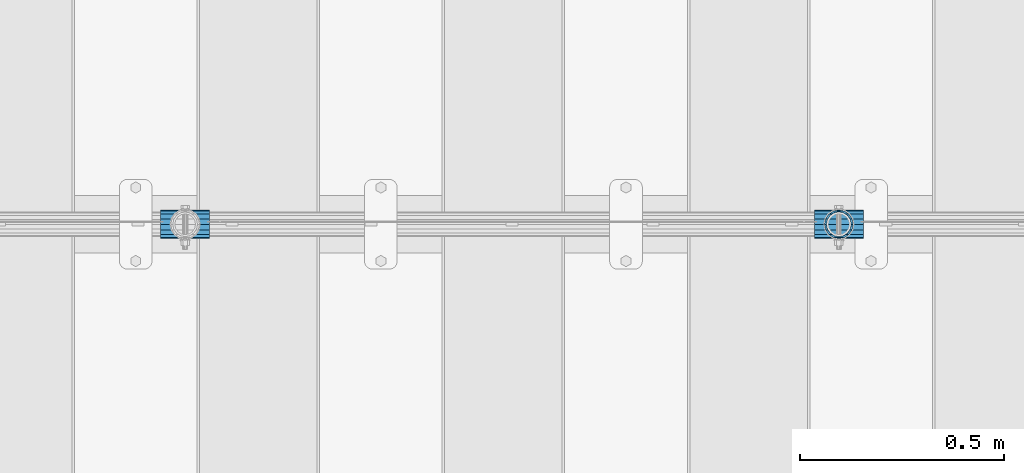
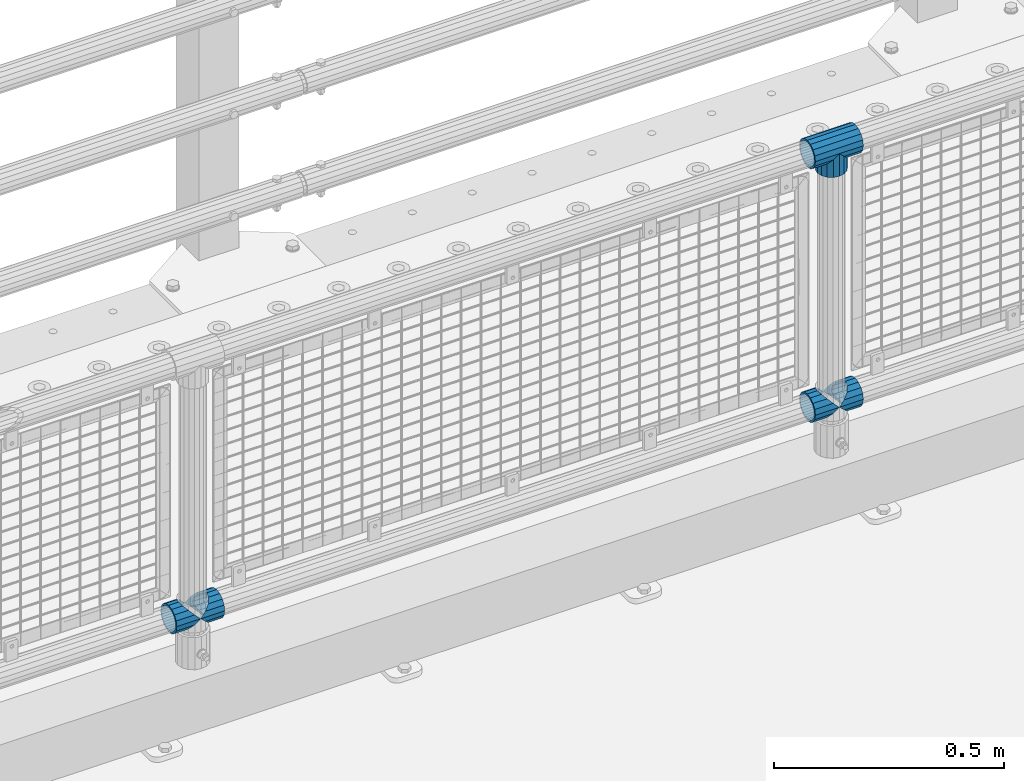
# One storey, part 153 of 247: 6 beams.
"""IFC2X3 building model written with IfcOpenShell, lengths in millimetres."""

from ifc_helpers import new_model, si_unit, frame, origin_with_axes, place, context, subcontext, project, spatial, faceted_brep, material, type_object, element, save


model = new_model("IFC2X3")

# Units and contexts
model_context = context("Model", 3, precision=1e-05, world=origin_with_axes())
body_context = subcontext(model_context, "Body", "Model", "MODEL_VIEW")
ifc_project = project(units=[si_unit("LENGTHUNIT", "METRE", prefix="MILLI"), si_unit("AREAUNIT", "SQUARE_METRE"), si_unit("VOLUMEUNIT", "CUBIC_METRE"), si_unit("MASSUNIT", "GRAM", prefix="KILO"), si_unit("TIMEUNIT", "SECOND"), si_unit("PLANEANGLEUNIT", "RADIAN"), si_unit("SOLIDANGLEUNIT", "STERADIAN"), si_unit("THERMODYNAMICTEMPERATUREUNIT", "DEGREE_CELSIUS"), si_unit("LUMINOUSINTENSITYUNIT", "LUMEN")], contexts=[model_context])

# Site, building, storey
site_placement = place(None, origin_with_axes())
site = spatial("IfcSite", under=ifc_project, at=site_placement, CompositionType="ELEMENT")
building_placement = place(site_placement, origin_with_axes())
building = spatial("IfcBuilding", under=site, at=building_placement, Name="Standard", CompositionType="ELEMENT")
storey_placement = place(building_placement, origin_with_axes())
storey = spatial("IfcBuildingStorey", under=building, at=storey_placement, Name="Undefined", CompositionType="ELEMENT", Elevation=0.0)

# Beams
ifc_material = material(Name="Misc_Undefined")
beam_type = type_object("IfcBeamType", PredefinedType="NOTDEFINED")
beam_1_placement = place(storey_placement, frame((10221.0, 7664.5, 969.849999999999), z_axis=(0.0, 1.0, 0.0), x_axis=(0.0, 0.0, -1.0)))
element("IfcBeam", 1, at=beam_1_placement, inside=storey, type_object=beam_type, material=ifc_material, context=body_context, shape_type="Brep", body=[
    faceted_brep([(0.0, 0.0, 35.1499999999996), (13.4513226476338, 13.4513226476329, 32.4743655677721), (13.4513226476338, -13.4513226476329, 32.4743655677721), (24.8548033587067, -16.3810424080045, -24.8548033587067), (24.8548033587067, -24.8548033587072, -24.8548033587067), (32.4743655677721, -32.4743655677717, -13.4513226476329), (32.4743655677721, -26.8123795176766, -13.4513226476329), (27.1226768591059, -21.4606908090117, -21.4606908090118), (0.0, 0.0, -35.1499999999996), (13.4513226476338, -13.4513226476329, -32.4743655677721), (13.4513226476338, 13.4513226476329, -32.4743655677721), (20.0882031229885, -11.6144421722805, -28.0397438117179), (16.6306603983739, 0.0, -30.3500000000004), (20.0882031229885, 11.6144421722805, -28.0397438117179), (24.8548033587067, 16.3810424080029, -24.8548033587067), (24.8548033587067, 24.8548033587072, -24.8548033587067), (27.1226768591059, 21.4606908090117, -21.4606908090118), (32.4743655677721, 26.8123795176755, -13.4513226476329), (32.4743655677721, 32.4743655677717, -13.4513226476329), (32.8397438117172, 28.0397438117175, -11.6144421722802), (35.1499999999996, 30.35, 0.0), (35.1499999999996, 35.15, 0.0), (32.8397438117172, 28.0397438117175, 11.6144421722802), (32.4743655677721, 26.8123795176755, 13.4513226476329), (32.4743655677721, 32.4743655677717, 13.4513226476329), (27.1226768591096, 21.4606908090117, 21.4606908090118), (24.8548033587067, 16.3810424080046, 24.8548033587067), (24.8548033587067, 24.8548033587072, 24.8548033587067), (20.0882031229812, 11.6144421722805, 28.0397438117179), (16.6306603983649, 0.0, 30.3500000000004), (20.0882031229812, -11.6144421722805, 28.0397438117179), (24.8548033587067, -16.3810424080045, 24.8548033587067), (24.8548033587067, -24.8548033587072, 24.8548033587067), (27.1226768591096, -21.4606908090117, 21.4606908090118), (32.4743655677721, -26.8123795176755, 13.4513226476329), (32.4743655677721, -32.4743655677717, 13.4513226476329), (32.8397438117172, -28.0397438117175, 11.6144421722802), (35.1499999999996, -30.35, 0.0), (35.1499999999996, -35.15, 0.0), (32.8397438117172, -28.0397438117175, -11.6144421722802), (60.1499999999996, -24.8548033587072, -24.8548033587067), (60.1499999999996, -32.4743655677717, -13.4513226476329), (60.1499999999996, -13.4513226476329, -32.4743655677721), (60.1499999999996, 0.0, -35.1499999999996), (60.1499999999996, 13.4513226476329, -32.4743655677721), (60.1499999999996, 24.8548033587072, -24.8548033587067), (60.1499999999996, 32.4743655677717, -13.4513226476329), (60.1499999999996, 35.15, 0.0), (60.1499999999996, 32.4743655677717, 13.4513226476329), (60.1499999999996, 24.8548033587072, 24.8548033587067), (60.1499999999996, 13.4513226476329, 32.4743655677721), (60.1499999999996, 0.0, 35.1499999999996), (60.1499999999996, -13.4513226476329, 32.4743655677721), (60.1499999999996, -24.8548033587072, 24.8548033587067), (60.1499999999996, -32.4743655677717, 13.4513226476329), (60.1499999999996, -35.15, 0.0), (60.1499999999996, -21.4606908090117, 21.4606908090118), (60.1499999999996, -11.6144421722805, 28.0397438117179), (60.1499999999996, 0.0, 30.3500000000004), (60.1499999999996, 11.6144421722805, 28.0397438117179), (60.1499999999996, 21.4606908090117, 21.4606908090118), (60.1499999999996, 28.0397438117175, 11.6144421722802), (60.1499999999996, 30.35, 0.0), (60.1499999999996, 28.0397438117175, -11.6144421722802), (60.1499999999996, 21.4606908090117, -21.4606908090118), (60.1499999999996, 11.6144421722805, -28.0397438117179), (60.1499999999996, 0.0, -30.3500000000004), (60.1499999999996, -11.6144421722805, -28.0397438117179), (60.1499999999996, -21.4606908090117, -21.4606908090118), (60.1499999999996, -28.0397438117175, -11.6144421722802), (60.1499999999996, -30.35, 0.0), (60.1499999999996, -28.0397438117175, 11.6144421722802)], [[[0, 1, 2]], [[3, 4, 5, 6, 7]], [[8, 9, 10]], [[10, 9, 4, 3, 11, 12, 13, 14, 15]], [[15, 14, 16, 17, 18]], [[18, 17, 19, 20, 21]], [[21, 20, 22, 23, 24]], [[24, 23, 25, 26, 27]], [[27, 26, 28, 29, 30, 31, 32, 2, 1]], [[33, 34, 35, 32, 31]], [[36, 37, 38, 35, 34]], [[6, 5, 38, 37, 39]], [[40, 41, 5, 4]], [[42, 40, 4, 9]], [[43, 42, 9, 8]], [[44, 43, 8, 10]], [[45, 44, 10, 15]], [[46, 45, 15, 18]], [[47, 46, 18, 21]], [[48, 47, 21, 24]], [[49, 48, 24, 27]], [[50, 49, 27, 1]], [[51, 50, 1, 0]], [[52, 51, 0, 2]], [[53, 52, 2, 32]], [[54, 53, 32, 35]], [[55, 54, 35, 38]], [[41, 55, 38, 5]], [[40, 42, 43, 44, 45, 46, 47, 48, 49, 50, 51, 52, 53, 54, 55, 41], [56, 57, 58, 59, 60, 61, 62, 63, 64, 65, 66, 67, 68, 69, 70, 71]], [[71, 70, 37, 36]], [[56, 71, 36, 34, 33]], [[57, 56, 33, 31, 30]], [[58, 57, 30, 29]], [[59, 58, 29, 28]], [[25, 60, 59, 28, 26]], [[22, 61, 60, 25, 23]], [[62, 61, 22, 20]], [[63, 62, 20, 19]], [[64, 63, 19, 17, 16]], [[65, 64, 16, 14, 13]], [[66, 65, 13, 12]], [[67, 66, 12, 11]], [[7, 68, 67, 11, 3]], [[39, 69, 68, 7, 6]], [[70, 69, 39, 37]]]),
])
beam_2_placement = place(storey_placement, frame((10160.85, 7664.5, 969.849999999999), z_axis=(0.0, 0.0, 1.0), x_axis=(1.0, 0.0, 0.0)))
element("IfcBeam", 2, at=beam_2_placement, inside=storey, type_object=beam_type, material=ifc_material, context=body_context, shape_type="Brep", body=[
    faceted_brep([(88.1897438117176, -11.6144421722802, -28.0397438117176), (88.1897438117176, -11.6144421722802, -32.8397438117175), (86.9623795176758, -13.4513226476329, -32.4743655677718), (81.6106908090114, -21.4606908090118, -27.1226768591068), (81.6106908090114, -21.4606908090118, -21.4606908090117), (76.5310424080035, -24.8548033587067, -24.8548033587072), (71.7644421722798, -28.0397438117179, -20.0882031229845), (71.7644421722798, -28.0397438117179, -11.6144421722805), (60.1499999999996, -30.3500000000004, -16.6306603983671), (60.1499999999996, -30.35, 0.0), (48.5355578277195, -28.0397438117179, -20.0882031229845), (48.5355578277195, -28.0397438117179, -11.6144421722805), (43.7689575919958, -24.8548033587067, -24.8548033587072), (38.6893091909878, -21.4606908090118, -27.1226768591068), (38.6893091909878, -21.4606908090118, -21.4606908090117), (33.3376204823217, -13.4513226476329, -32.4743655677718), (32.1102561882817, -11.6144421722802, -32.8397438117175), (32.1102561882817, -11.6144421722802, -28.0397438117176), (29.7999999999993, 0.0, -35.15), (29.7999999999993, 0.0, -30.35), (32.1102561882817, 11.6144421722802, -32.8397438117174), (32.1102561882817, 11.6144421722802, -28.0397438117176), (33.3376204823235, 13.4513226476329, -32.4743655677718), (38.6893091909878, 21.4606908090118, -27.122676859108), (38.6893091909878, 21.4606908090118, -21.4606908090117), (43.7689575919976, 24.8548033587067, -24.8548033587072), (48.5355578277195, 28.0397438117179, -20.0882031229829), (48.5355578277195, 28.0397438117179, -11.6144421722805), (60.1499999999996, 30.3500000000004, -16.6306603983655), (60.1499999999996, 30.35, 0.0), (71.7644421722798, 28.0397438117179, -20.0882031229829), (71.7644421722798, 28.0397438117179, -11.6144421722805), (76.5310424080035, 24.8548033587067, -24.8548033587072), (81.6106908090114, 21.4606908090118, -27.122676859108), (81.6106908090114, 21.4606908090118, -21.4606908090117), (86.9623795176758, 13.4513226476329, -32.4743655677718), (88.1897438117176, 11.6144421722802, -32.8397438117174), (88.1897438117176, 11.6144421722802, -28.0397438117176), (90.5, 0.0, -35.15), (90.5, 0.0, -30.35), (0.0, -21.4606908090118, -21.4606908090118), (0.0, -28.0397438117179, -11.6144421722802), (0.0, -11.6144421722802, -28.0397438117179), (0.0, 0.0, -30.3500000000004), (0.0, 11.6144421722802, -28.0397438117179), (0.0, 21.4606908090118, -21.4606908090118), (0.0, 28.0397438117179, -11.6144421722802), (0.0, 30.3500000000004, 0.0), (0.0, 32.4743655677721, -13.4513226476338), (0.0, 35.1499999999996, 0.0), (120.299999999999, 35.1499999999996, 0.0), (120.299999999999, 32.4743655677721, -13.4513226476329), (0.0, 32.4743655677721, 13.4513226476338), (120.299999999999, 32.4743655677721, 13.4513226476329), (0.0, 24.8548033587067, 24.8548033587067), (120.299999999999, 24.8548033587067, 24.8548033587072), (0.0, 13.4513226476329, 32.4743655677721), (120.299999999999, 13.4513226476329, 32.4743655677718), (0.0, 0.0, 35.1499999999996), (120.299999999999, 0.0, 35.15), (0.0, -13.4513226476329, 32.4743655677721), (120.299999999999, -13.4513226476329, 32.4743655677718), (0.0, -24.8548033587067, 24.8548033587067), (120.299999999999, -24.8548033587067, 24.8548033587072), (0.0, -32.4743655677721, 13.4513226476338), (120.299999999999, -32.4743655677721, 13.4513226476329), (0.0, -35.1499999999996, 0.0), (120.299999999999, -35.1499999999996, 0.0), (0.0, -32.4743655677721, -13.4513226476338), (120.299999999999, -32.4743655677721, -13.4513226476329), (0.0, 24.8548033587067, -24.8548033587067), (0.0, 13.4513226476329, -32.4743655677721), (0.0, 0.0, -35.1499999999996), (0.0, -13.4513226476329, -32.4743655677721), (0.0, -24.8548033587067, -24.8548033587067), (0.0, 28.0397438117179, 11.6144421722802), (0.0, 21.4606908090118, 21.4606908090118), (0.0, 11.6144421722802, 28.0397438117179), (0.0, 0.0, 30.3500000000004), (0.0, -11.6144421722802, 28.0397438117179), (0.0, -21.4606908090118, 21.4606908090118), (0.0, -28.0397438117179, 11.6144421722802), (0.0, -30.3500000000004, 0.0), (120.299999999999, -30.3500000000004, 0.0), (120.299999999999, -28.0397438117179, -11.6144421722805), (120.299999999999, -21.4606908090118, -21.4606908090117), (120.299999999999, -11.6144421722802, -28.0397438117176), (120.299999999999, 0.0, -30.35), (120.299999999999, 21.4606908090118, -21.4606908090117), (120.299999999999, 28.0397438117179, -11.6144421722805), (120.299999999999, 11.6144421722802, -28.0397438117176), (120.299999999999, 30.3500000000004, 0.0), (120.299999999999, 28.0397438117179, 11.6144421722805), (120.299999999999, 21.4606908090118, 21.4606908090117), (120.299999999999, 11.6144421722802, 28.0397438117176), (120.299999999999, 0.0, 30.35), (120.299999999999, -11.6144421722802, 28.0397438117176), (120.299999999999, -21.4606908090118, 21.4606908090117), (120.299999999999, -28.0397438117179, 11.6144421722805), (120.299999999999, -24.8548033587067, -24.8548033587072), (120.299999999999, -13.4513226476329, -32.4743655677718), (120.299999999999, 0.0, -35.15), (120.299999999999, 13.4513226476329, -32.4743655677718), (120.299999999999, 24.8548033587067, -24.8548033587072)], [[[0, 1, 2, 3, 4]], [[4, 3, 5, 6, 7]], [[7, 6, 8, 9]], [[9, 8, 10, 11]], [[11, 10, 12, 13, 14]], [[14, 13, 15, 16, 17]], [[17, 16, 18, 19]], [[19, 18, 20, 21]], [[21, 20, 22, 23, 24]], [[24, 23, 25, 26, 27]], [[27, 26, 28, 29]], [[29, 28, 30, 31]], [[31, 30, 32, 33, 34]], [[34, 33, 35, 36, 37]], [[37, 36, 38, 39]], [[39, 38, 1, 0]], [[40, 41, 11, 14]], [[42, 40, 14, 17]], [[43, 42, 17, 19]], [[44, 43, 19, 21]], [[45, 44, 21, 24]], [[46, 45, 24, 27]], [[47, 46, 27, 29]], [[48, 49, 50, 51]], [[49, 52, 53, 50]], [[52, 54, 55, 53]], [[54, 56, 57, 55]], [[56, 58, 59, 57]], [[58, 60, 61, 59]], [[60, 62, 63, 61]], [[62, 64, 65, 63]], [[64, 66, 67, 65]], [[66, 68, 69, 67]], [[64, 62, 60, 58, 56, 54, 52, 49, 48, 70, 71, 72, 73, 74, 68, 66], [41, 40, 42, 43, 44, 45, 46, 47, 75, 76, 77, 78, 79, 80, 81, 82]], [[41, 82, 9, 11]], [[83, 84, 7, 9]], [[84, 85, 4, 7]], [[85, 86, 0, 4]], [[86, 87, 39, 0]], [[88, 89, 31, 34]], [[90, 88, 34, 37]], [[87, 90, 37, 39]], [[89, 91, 29, 31]], [[75, 47, 29, 91, 92]], [[76, 75, 92, 93]], [[77, 76, 93, 94]], [[78, 77, 94, 95]], [[79, 78, 95, 96]], [[80, 79, 96, 97]], [[81, 80, 97, 98]], [[9, 82, 81, 98, 83]], [[99, 100, 101, 102, 103, 51, 50, 53, 55, 57, 59, 61, 63, 65, 67, 69], [97, 96, 95, 94, 93, 92, 91, 89, 88, 90, 87, 86, 85, 84, 83, 98]], [[35, 102, 101, 38, 36]], [[32, 103, 102, 35, 33]], [[28, 26, 25, 70, 48, 51, 103, 32, 30]], [[22, 71, 70, 25, 23]], [[18, 72, 71, 22, 20]], [[73, 72, 18, 16, 15]], [[74, 73, 15, 13, 12]], [[99, 69, 68, 74, 12, 10, 8, 6, 5]], [[100, 99, 5, 3, 2]], [[101, 100, 2, 1, 38]]]),
])
beam_3_placement = place(storey_placement, frame((10160.85, 7664.5, 298.17), z_axis=(0.0, 1.0, 0.0), x_axis=(1.0, 0.0, 0.0)))
element("IfcBeam", 3, at=beam_3_placement, inside=storey, type_object=beam_type, material=ifc_material, context=body_context, shape_type="Brep", body=[
    faceted_brep([(60.1499999999996, 0.0, -35.1499999999996), (46.6986773523668, 13.4513226476329, -32.4743655677721), (46.6986773523668, -13.4513226476329, -32.4743655677721), (33.0273231408919, 21.4606908090117, 21.4606908090118), (27.675634432228, 26.8123795176755, 13.4513226476329), (27.675634432228, 32.4743655677717, 13.4513226476329), (35.2951966412925, 24.8548033587072, 24.8548033587067), (35.2951966412925, 16.3810424080048, 24.8548033587067), (27.3102561882824, 28.0397438117175, 11.6144421722802), (24.9999999999995, 30.35, 0.0), (24.9999999999995, 35.15, 0.0), (27.675634432228, 26.8123795176764, -13.4513226476329), (27.675634432228, 32.4743655677717, -13.4513226476329), (27.310256188282, 28.0397438117175, -11.6144421722802), (35.2951966412925, 16.3810424080032, -24.8548033587067), (35.2951966412925, 24.8548033587072, -24.8548033587067), (33.0273231408928, 21.4606908090117, -21.4606908090118), (40.0617968770157, 11.6144421722805, -28.0397438117179), (43.5193396016348, 0.0, -30.3500000000004), (40.0617968770157, -11.6144421722805, -28.0397438117179), (35.2951966412925, -16.3810424080032, -24.8548033587067), (35.2951966412925, -24.8548033587072, -24.8548033587067), (33.0273231408928, -21.4606908090117, -21.4606908090118), (27.675634432228, -26.8123795176766, -13.4513226476329), (27.675634432228, -32.4743655677717, -13.4513226476329), (27.310256188282, -28.0397438117175, -11.6144421722802), (24.9999999999995, -30.35, 0.0), (24.9999999999995, -35.15, 0.0), (27.3102561882824, -28.0397438117175, 11.6144421722802), (27.675634432228, -26.8123795176764, 13.4513226476329), (27.675634432228, -32.4743655677717, 13.4513226476329), (33.0273231408919, -21.4606908090117, 21.4606908090118), (35.2951966412925, -16.3810424080032, 24.8548033587067), (35.2951966412925, -24.8548033587072, 24.8548033587067), (60.1499999999996, 0.0, 35.1499999999996), (46.6986773523668, -13.4513226476329, 32.4743655677721), (46.6986773523668, 13.4513226476329, 32.4743655677721), (40.0617968770157, -11.6144421722805, 28.0397438117179), (43.519339601633, 0.0, 30.3500000000004), (40.0617968770157, 11.6144421722805, 28.0397438117179), (0.0, -32.4743655677721, -13.4513226476338), (0.0, -24.8548033587067, -24.8548033587067), (0.0, -13.4513226476329, -32.4743655677721), (0.0, 0.0, -35.1499999999996), (0.0, 13.4513226476329, -32.4743655677721), (0.0, 24.8548033587067, -24.8548033587067), (0.0, 32.4743655677721, -13.4513226476338), (0.0, 35.1499999999996, 0.0), (0.0, 32.4743655677721, 13.4513226476338), (0.0, 24.8548033587067, 24.8548033587067), (0.0, 13.4513226476329, 32.4743655677721), (0.0, 0.0, 35.1499999999996), (0.0, -32.4743655677721, 13.4513226476338), (0.0, -35.1499999999996, 0.0), (0.0, -24.8548033587067, 24.8548033587067), (0.0, -13.4513226476329, 32.4743655677721), (0.0, -28.0397438117179, -11.6144421722802), (0.0, -21.4606908090118, -21.4606908090118), (0.0, -11.6144421722802, -28.0397438117179), (0.0, 0.0, -30.3500000000004), (0.0, 11.6144421722802, -28.0397438117179), (0.0, 21.4606908090118, -21.4606908090118), (0.0, 28.0397438117179, -11.6144421722802), (0.0, 30.3500000000004, 0.0), (0.0, 28.0397438117179, 11.6144421722802), (0.0, 21.4606908090118, 21.4606908090118), (0.0, 11.6144421722802, 28.0397438117179), (0.0, 0.0, 30.3500000000004), (0.0, -11.6144421722802, 28.0397438117179), (0.0, -21.4606908090118, 21.4606908090118), (0.0, -28.0397438117179, 11.6144421722802), (0.0, -30.3500000000004, 0.0)], [[[0, 1, 2]], [[3, 4, 5, 6, 7]], [[8, 9, 10, 5, 4]], [[11, 12, 10, 9, 13]], [[14, 15, 12, 11, 16]], [[2, 1, 15, 14, 17, 18, 19, 20, 21]], [[21, 20, 22, 23, 24]], [[24, 23, 25, 26, 27]], [[27, 26, 28, 29, 30]], [[30, 29, 31, 32, 33]], [[34, 35, 36]], [[33, 32, 37, 38, 39, 7, 6, 36, 35]], [[40, 41, 21, 24]], [[41, 42, 2, 21]], [[42, 43, 0, 2]], [[43, 44, 1, 0]], [[44, 45, 15, 1]], [[45, 46, 12, 15]], [[46, 47, 10, 12]], [[47, 48, 5, 10]], [[48, 49, 6, 5]], [[49, 50, 36, 6]], [[50, 51, 34, 36]], [[52, 53, 27, 30]], [[54, 52, 30, 33]], [[55, 54, 33, 35]], [[51, 55, 35, 34]], [[53, 40, 24, 27]], [[52, 54, 55, 51, 50, 49, 48, 47, 46, 45, 44, 43, 42, 41, 40, 53], [56, 57, 58, 59, 60, 61, 62, 63, 64, 65, 66, 67, 68, 69, 70, 71]], [[68, 67, 38, 37]], [[31, 69, 68, 37, 32]], [[28, 70, 69, 31, 29]], [[71, 70, 28, 26]], [[56, 71, 26, 25]], [[57, 56, 25, 23, 22]], [[58, 57, 22, 20, 19]], [[59, 58, 19, 18]], [[60, 59, 18, 17]], [[16, 61, 60, 17, 14]], [[13, 62, 61, 16, 11]], [[63, 62, 13, 9]], [[64, 63, 9, 8]], [[65, 64, 8, 4, 3]], [[66, 65, 3, 7, 39]], [[67, 66, 39, 38]]]),
])
beam_4_placement = place(storey_placement, frame((10221.0, 7664.5, 298.17), z_axis=(0.0, 1.0, 0.0), x_axis=(1.0, 0.0, 0.0)))
element("IfcBeam", 4, at=beam_4_placement, inside=storey, type_object=beam_type, material=ifc_material, context=body_context, shape_type="Brep", body=[
    faceted_brep([(0.0, 0.0, 35.1499999999996), (13.4513226476338, 13.4513226476329, 32.4743655677721), (13.4513226476338, -13.4513226476329, 32.4743655677721), (24.8548033587067, -16.3810424080045, -24.8548033587067), (24.8548033587067, -24.8548033587072, -24.8548033587067), (32.4743655677721, -32.4743655677717, -13.4513226476329), (32.4743655677721, -26.8123795176766, -13.4513226476329), (27.1226768591059, -21.4606908090117, -21.4606908090118), (0.0, 0.0, -35.1499999999996), (13.4513226476338, -13.4513226476329, -32.4743655677721), (13.4513226476338, 13.4513226476329, -32.4743655677721), (20.0882031229885, -11.6144421722805, -28.0397438117179), (16.6306603983739, 0.0, -30.3500000000004), (20.0882031229885, 11.6144421722805, -28.0397438117179), (24.8548033587067, 16.3810424080029, -24.8548033587067), (24.8548033587067, 24.8548033587072, -24.8548033587067), (27.1226768591059, 21.4606908090117, -21.4606908090118), (32.4743655677721, 26.8123795176755, -13.4513226476329), (32.4743655677721, 32.4743655677717, -13.4513226476329), (32.8397438117172, 28.0397438117175, -11.6144421722802), (35.1499999999996, 30.35, 0.0), (35.1499999999996, 35.15, 0.0), (32.8397438117172, 28.0397438117175, 11.6144421722802), (32.4743655677721, 26.8123795176755, 13.4513226476329), (32.4743655677721, 32.4743655677717, 13.4513226476329), (27.1226768591096, 21.4606908090117, 21.4606908090118), (24.8548033587067, 16.3810424080046, 24.8548033587067), (24.8548033587067, 24.8548033587072, 24.8548033587067), (20.0882031229812, 11.6144421722805, 28.0397438117179), (16.6306603983649, 0.0, 30.3500000000004), (20.0882031229812, -11.6144421722805, 28.0397438117179), (24.8548033587067, -16.3810424080045, 24.8548033587067), (24.8548033587067, -24.8548033587072, 24.8548033587067), (27.1226768591096, -21.4606908090117, 21.4606908090118), (32.4743655677721, -26.8123795176755, 13.4513226476329), (32.4743655677721, -32.4743655677717, 13.4513226476329), (32.8397438117172, -28.0397438117175, 11.6144421722802), (35.1499999999996, -30.35, 0.0), (35.1499999999996, -35.15, 0.0), (32.8397438117172, -28.0397438117175, -11.6144421722802), (60.1499999999996, -24.8548033587072, -24.8548033587067), (60.1499999999996, -32.4743655677717, -13.4513226476329), (60.1499999999996, -13.4513226476329, -32.4743655677721), (60.1499999999996, 0.0, -35.1499999999996), (60.1499999999996, 13.4513226476329, -32.4743655677721), (60.1499999999996, 24.8548033587072, -24.8548033587067), (60.1499999999996, 32.4743655677717, -13.4513226476329), (60.1499999999996, 35.15, 0.0), (60.1499999999996, 32.4743655677717, 13.4513226476329), (60.1499999999996, 24.8548033587072, 24.8548033587067), (60.1499999999996, 13.4513226476329, 32.4743655677721), (60.1499999999996, 0.0, 35.1499999999996), (60.1499999999996, -13.4513226476329, 32.4743655677721), (60.1499999999996, -24.8548033587072, 24.8548033587067), (60.1499999999996, -32.4743655677717, 13.4513226476329), (60.1499999999996, -35.15, 0.0), (60.1499999999996, -21.4606908090117, 21.4606908090118), (60.1499999999996, -11.6144421722805, 28.0397438117179), (60.1499999999996, 0.0, 30.3500000000004), (60.1499999999996, 11.6144421722805, 28.0397438117179), (60.1499999999996, 21.4606908090117, 21.4606908090118), (60.1499999999996, 28.0397438117175, 11.6144421722802), (60.1499999999996, 30.35, 0.0), (60.1499999999996, 28.0397438117175, -11.6144421722802), (60.1499999999996, 21.4606908090117, -21.4606908090118), (60.1499999999996, 11.6144421722805, -28.0397438117179), (60.1499999999996, 0.0, -30.3500000000004), (60.1499999999996, -11.6144421722805, -28.0397438117179), (60.1499999999996, -21.4606908090117, -21.4606908090118), (60.1499999999996, -28.0397438117175, -11.6144421722802), (60.1499999999996, -30.35, 0.0), (60.1499999999996, -28.0397438117175, 11.6144421722802)], [[[0, 1, 2]], [[3, 4, 5, 6, 7]], [[8, 9, 10]], [[10, 9, 4, 3, 11, 12, 13, 14, 15]], [[15, 14, 16, 17, 18]], [[18, 17, 19, 20, 21]], [[21, 20, 22, 23, 24]], [[24, 23, 25, 26, 27]], [[27, 26, 28, 29, 30, 31, 32, 2, 1]], [[33, 34, 35, 32, 31]], [[36, 37, 38, 35, 34]], [[6, 5, 38, 37, 39]], [[40, 41, 5, 4]], [[42, 40, 4, 9]], [[43, 42, 9, 8]], [[44, 43, 8, 10]], [[45, 44, 10, 15]], [[46, 45, 15, 18]], [[47, 46, 18, 21]], [[48, 47, 21, 24]], [[49, 48, 24, 27]], [[50, 49, 27, 1]], [[51, 50, 1, 0]], [[52, 51, 0, 2]], [[53, 52, 2, 32]], [[54, 53, 32, 35]], [[55, 54, 35, 38]], [[41, 55, 38, 5]], [[40, 42, 43, 44, 45, 46, 47, 48, 49, 50, 51, 52, 53, 54, 55, 41], [56, 57, 58, 59, 60, 61, 62, 63, 64, 65, 66, 67, 68, 69, 70, 71]], [[71, 70, 37, 36]], [[56, 71, 36, 34, 33]], [[57, 56, 33, 31, 30]], [[58, 57, 30, 29]], [[59, 58, 29, 28]], [[25, 60, 59, 28, 26]], [[22, 61, 60, 25, 23]], [[62, 61, 22, 20]], [[63, 62, 20, 19]], [[64, 63, 19, 17, 16]], [[65, 64, 16, 14, 13]], [[66, 65, 13, 12]], [[67, 66, 12, 11]], [[7, 68, 67, 11, 3]], [[39, 69, 68, 7, 6]], [[70, 69, 39, 37]]]),
])
beam_5_placement = place(storey_placement, frame((8560.85, 7664.5, 298.17), z_axis=(0.0, 1.0, 0.0), x_axis=(1.0, 0.0, 0.0)))
element("IfcBeam", 5, at=beam_5_placement, inside=storey, type_object=beam_type, material=ifc_material, context=body_context, shape_type="Brep", body=[
    faceted_brep([(60.1499999999996, 0.0, -35.1499999999996), (46.6986773523668, 13.4513226476329, -32.4743655677721), (46.6986773523668, -13.4513226476329, -32.4743655677721), (33.0273231408919, 21.4606908090117, 21.4606908090118), (27.675634432228, 26.8123795176755, 13.4513226476329), (27.675634432228, 32.4743655677717, 13.4513226476329), (35.2951966412925, 24.8548033587072, 24.8548033587067), (35.2951966412925, 16.3810424080048, 24.8548033587067), (27.3102561882824, 28.0397438117175, 11.6144421722802), (24.9999999999995, 30.35, 0.0), (24.9999999999995, 35.15, 0.0), (27.675634432228, 26.8123795176764, -13.4513226476329), (27.675634432228, 32.4743655677717, -13.4513226476329), (27.310256188282, 28.0397438117175, -11.6144421722802), (35.2951966412925, 16.3810424080032, -24.8548033587067), (35.2951966412925, 24.8548033587072, -24.8548033587067), (33.0273231408928, 21.4606908090117, -21.4606908090118), (40.0617968770157, 11.6144421722805, -28.0397438117179), (43.5193396016348, 0.0, -30.3500000000004), (40.0617968770157, -11.6144421722805, -28.0397438117179), (35.2951966412925, -16.3810424080032, -24.8548033587067), (35.2951966412925, -24.8548033587072, -24.8548033587067), (33.0273231408928, -21.4606908090117, -21.4606908090118), (27.675634432228, -26.8123795176766, -13.4513226476329), (27.675634432228, -32.4743655677717, -13.4513226476329), (27.310256188282, -28.0397438117175, -11.6144421722802), (24.9999999999995, -30.35, 0.0), (24.9999999999995, -35.15, 0.0), (27.3102561882824, -28.0397438117175, 11.6144421722802), (27.675634432228, -26.8123795176764, 13.4513226476329), (27.675634432228, -32.4743655677717, 13.4513226476329), (33.0273231408919, -21.4606908090117, 21.4606908090118), (35.2951966412925, -16.3810424080032, 24.8548033587067), (35.2951966412925, -24.8548033587072, 24.8548033587067), (60.1499999999996, 0.0, 35.1499999999996), (46.6986773523668, -13.4513226476329, 32.4743655677721), (46.6986773523668, 13.4513226476329, 32.4743655677721), (40.0617968770157, -11.6144421722805, 28.0397438117179), (43.519339601633, 0.0, 30.3500000000004), (40.0617968770157, 11.6144421722805, 28.0397438117179), (0.0, -32.4743655677721, -13.4513226476338), (0.0, -24.8548033587067, -24.8548033587067), (0.0, -13.4513226476329, -32.4743655677721), (0.0, 0.0, -35.1499999999996), (0.0, 13.4513226476329, -32.4743655677721), (0.0, 24.8548033587067, -24.8548033587067), (0.0, 32.4743655677721, -13.4513226476338), (0.0, 35.1499999999996, 0.0), (0.0, 32.4743655677721, 13.4513226476338), (0.0, 24.8548033587067, 24.8548033587067), (0.0, 13.4513226476329, 32.4743655677721), (0.0, 0.0, 35.1499999999996), (0.0, -32.4743655677721, 13.4513226476338), (0.0, -35.1499999999996, 0.0), (0.0, -24.8548033587067, 24.8548033587067), (0.0, -13.4513226476329, 32.4743655677721), (0.0, -28.0397438117179, -11.6144421722802), (0.0, -21.4606908090118, -21.4606908090118), (0.0, -11.6144421722802, -28.0397438117179), (0.0, 0.0, -30.3500000000004), (0.0, 11.6144421722802, -28.0397438117179), (0.0, 21.4606908090118, -21.4606908090118), (0.0, 28.0397438117179, -11.6144421722802), (0.0, 30.3500000000004, 0.0), (0.0, 28.0397438117179, 11.6144421722802), (0.0, 21.4606908090118, 21.4606908090118), (0.0, 11.6144421722802, 28.0397438117179), (0.0, 0.0, 30.3500000000004), (0.0, -11.6144421722802, 28.0397438117179), (0.0, -21.4606908090118, 21.4606908090118), (0.0, -28.0397438117179, 11.6144421722802), (0.0, -30.3500000000004, 0.0)], [[[0, 1, 2]], [[3, 4, 5, 6, 7]], [[8, 9, 10, 5, 4]], [[11, 12, 10, 9, 13]], [[14, 15, 12, 11, 16]], [[2, 1, 15, 14, 17, 18, 19, 20, 21]], [[21, 20, 22, 23, 24]], [[24, 23, 25, 26, 27]], [[27, 26, 28, 29, 30]], [[30, 29, 31, 32, 33]], [[34, 35, 36]], [[33, 32, 37, 38, 39, 7, 6, 36, 35]], [[40, 41, 21, 24]], [[41, 42, 2, 21]], [[42, 43, 0, 2]], [[43, 44, 1, 0]], [[44, 45, 15, 1]], [[45, 46, 12, 15]], [[46, 47, 10, 12]], [[47, 48, 5, 10]], [[48, 49, 6, 5]], [[49, 50, 36, 6]], [[50, 51, 34, 36]], [[52, 53, 27, 30]], [[54, 52, 30, 33]], [[55, 54, 33, 35]], [[51, 55, 35, 34]], [[53, 40, 24, 27]], [[52, 54, 55, 51, 50, 49, 48, 47, 46, 45, 44, 43, 42, 41, 40, 53], [56, 57, 58, 59, 60, 61, 62, 63, 64, 65, 66, 67, 68, 69, 70, 71]], [[68, 67, 38, 37]], [[31, 69, 68, 37, 32]], [[28, 70, 69, 31, 29]], [[71, 70, 28, 26]], [[56, 71, 26, 25]], [[57, 56, 25, 23, 22]], [[58, 57, 22, 20, 19]], [[59, 58, 19, 18]], [[60, 59, 18, 17]], [[16, 61, 60, 17, 14]], [[13, 62, 61, 16, 11]], [[63, 62, 13, 9]], [[64, 63, 9, 8]], [[65, 64, 8, 4, 3]], [[66, 65, 3, 7, 39]], [[67, 66, 39, 38]]]),
])
beam_6_placement = place(storey_placement, frame((8621.0, 7664.5, 298.17), z_axis=(0.0, 1.0, 0.0), x_axis=(1.0, 0.0, 0.0)))
element("IfcBeam", 6, at=beam_6_placement, inside=storey, type_object=beam_type, material=ifc_material, context=body_context, shape_type="Brep", body=[
    faceted_brep([(0.0, 0.0, 35.1499999999996), (13.4513226476338, 13.4513226476329, 32.4743655677721), (13.4513226476338, -13.4513226476329, 32.4743655677721), (24.8548033587067, -16.3810424080045, -24.8548033587067), (24.8548033587067, -24.8548033587072, -24.8548033587067), (32.4743655677721, -32.4743655677717, -13.4513226476329), (32.4743655677721, -26.8123795176766, -13.4513226476329), (27.1226768591059, -21.4606908090117, -21.4606908090118), (0.0, 0.0, -35.1499999999996), (13.4513226476338, -13.4513226476329, -32.4743655677721), (13.4513226476338, 13.4513226476329, -32.4743655677721), (20.0882031229885, -11.6144421722805, -28.0397438117179), (16.6306603983739, 0.0, -30.3500000000004), (20.0882031229885, 11.6144421722805, -28.0397438117179), (24.8548033587067, 16.3810424080029, -24.8548033587067), (24.8548033587067, 24.8548033587072, -24.8548033587067), (27.1226768591059, 21.4606908090117, -21.4606908090118), (32.4743655677721, 26.8123795176755, -13.4513226476329), (32.4743655677721, 32.4743655677717, -13.4513226476329), (32.8397438117172, 28.0397438117175, -11.6144421722802), (35.1499999999996, 30.35, 0.0), (35.1499999999996, 35.15, 0.0), (32.8397438117172, 28.0397438117175, 11.6144421722802), (32.4743655677721, 26.8123795176755, 13.4513226476329), (32.4743655677721, 32.4743655677717, 13.4513226476329), (27.1226768591096, 21.4606908090117, 21.4606908090118), (24.8548033587067, 16.3810424080046, 24.8548033587067), (24.8548033587067, 24.8548033587072, 24.8548033587067), (20.0882031229812, 11.6144421722805, 28.0397438117179), (16.6306603983649, 0.0, 30.3500000000004), (20.0882031229812, -11.6144421722805, 28.0397438117179), (24.8548033587067, -16.3810424080045, 24.8548033587067), (24.8548033587067, -24.8548033587072, 24.8548033587067), (27.1226768591096, -21.4606908090117, 21.4606908090118), (32.4743655677721, -26.8123795176755, 13.4513226476329), (32.4743655677721, -32.4743655677717, 13.4513226476329), (32.8397438117172, -28.0397438117175, 11.6144421722802), (35.1499999999996, -30.35, 0.0), (35.1499999999996, -35.15, 0.0), (32.8397438117172, -28.0397438117175, -11.6144421722802), (60.1499999999996, -24.8548033587072, -24.8548033587067), (60.1499999999996, -32.4743655677717, -13.4513226476329), (60.1499999999996, -13.4513226476329, -32.4743655677721), (60.1499999999996, 0.0, -35.1499999999996), (60.1499999999996, 13.4513226476329, -32.4743655677721), (60.1499999999996, 24.8548033587072, -24.8548033587067), (60.1499999999996, 32.4743655677717, -13.4513226476329), (60.1499999999996, 35.15, 0.0), (60.1499999999996, 32.4743655677717, 13.4513226476329), (60.1499999999996, 24.8548033587072, 24.8548033587067), (60.1499999999996, 13.4513226476329, 32.4743655677721), (60.1499999999996, 0.0, 35.1499999999996), (60.1499999999996, -13.4513226476329, 32.4743655677721), (60.1499999999996, -24.8548033587072, 24.8548033587067), (60.1499999999996, -32.4743655677717, 13.4513226476329), (60.1499999999996, -35.15, 0.0), (60.1499999999996, -21.4606908090117, 21.4606908090118), (60.1499999999996, -11.6144421722805, 28.0397438117179), (60.1499999999996, 0.0, 30.3500000000004), (60.1499999999996, 11.6144421722805, 28.0397438117179), (60.1499999999996, 21.4606908090117, 21.4606908090118), (60.1499999999996, 28.0397438117175, 11.6144421722802), (60.1499999999996, 30.35, 0.0), (60.1499999999996, 28.0397438117175, -11.6144421722802), (60.1499999999996, 21.4606908090117, -21.4606908090118), (60.1499999999996, 11.6144421722805, -28.0397438117179), (60.1499999999996, 0.0, -30.3500000000004), (60.1499999999996, -11.6144421722805, -28.0397438117179), (60.1499999999996, -21.4606908090117, -21.4606908090118), (60.1499999999996, -28.0397438117175, -11.6144421722802), (60.1499999999996, -30.35, 0.0), (60.1499999999996, -28.0397438117175, 11.6144421722802)], [[[0, 1, 2]], [[3, 4, 5, 6, 7]], [[8, 9, 10]], [[10, 9, 4, 3, 11, 12, 13, 14, 15]], [[15, 14, 16, 17, 18]], [[18, 17, 19, 20, 21]], [[21, 20, 22, 23, 24]], [[24, 23, 25, 26, 27]], [[27, 26, 28, 29, 30, 31, 32, 2, 1]], [[33, 34, 35, 32, 31]], [[36, 37, 38, 35, 34]], [[6, 5, 38, 37, 39]], [[40, 41, 5, 4]], [[42, 40, 4, 9]], [[43, 42, 9, 8]], [[44, 43, 8, 10]], [[45, 44, 10, 15]], [[46, 45, 15, 18]], [[47, 46, 18, 21]], [[48, 47, 21, 24]], [[49, 48, 24, 27]], [[50, 49, 27, 1]], [[51, 50, 1, 0]], [[52, 51, 0, 2]], [[53, 52, 2, 32]], [[54, 53, 32, 35]], [[55, 54, 35, 38]], [[41, 55, 38, 5]], [[40, 42, 43, 44, 45, 46, 47, 48, 49, 50, 51, 52, 53, 54, 55, 41], [56, 57, 58, 59, 60, 61, 62, 63, 64, 65, 66, 67, 68, 69, 70, 71]], [[71, 70, 37, 36]], [[56, 71, 36, 34, 33]], [[57, 56, 33, 31, 30]], [[58, 57, 30, 29]], [[59, 58, 29, 28]], [[25, 60, 59, 28, 26]], [[22, 61, 60, 25, 23]], [[62, 61, 22, 20]], [[63, 62, 20, 19]], [[64, 63, 19, 17, 16]], [[65, 64, 16, 14, 13]], [[66, 65, 13, 12]], [[67, 66, 12, 11]], [[7, 68, 67, 11, 3]], [[39, 69, 68, 7, 6]], [[70, 69, 39, 37]]]),
])

save(model, "model.ifc")
